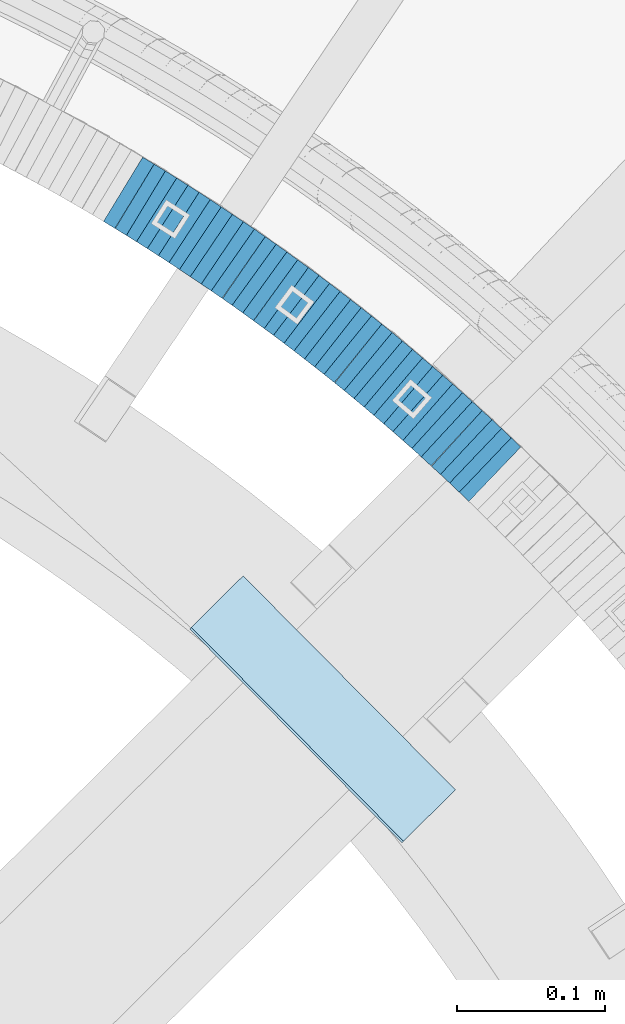
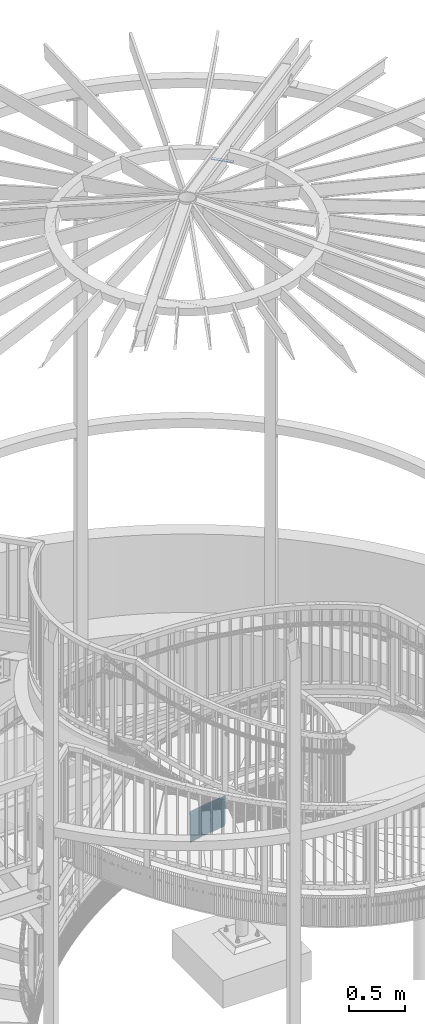
# One storey, part 899 of 975: 37 plates.
"""IFC2X3 building model written with IfcOpenShell, lengths in millimetres."""

from ifc_helpers import new_model, si_unit, frame, origin_with_axes, place, context, subcontext, project, spatial, faceted_brep, material, type_object, element, save


model = new_model("IFC2X3")

# Units and contexts
model_context = context("Model", 3, precision=1e-05, world=origin_with_axes())
body_context = subcontext(model_context, "Body", "Model", "MODEL_VIEW")
ifc_project = project(units=[si_unit("LENGTHUNIT", "METRE", prefix="MILLI"), si_unit("AREAUNIT", "SQUARE_METRE"), si_unit("VOLUMEUNIT", "CUBIC_METRE"), si_unit("MASSUNIT", "GRAM", prefix="KILO"), si_unit("TIMEUNIT", "SECOND"), si_unit("PLANEANGLEUNIT", "RADIAN"), si_unit("SOLIDANGLEUNIT", "STERADIAN"), si_unit("THERMODYNAMICTEMPERATUREUNIT", "DEGREE_CELSIUS"), si_unit("LUMINOUSINTENSITYUNIT", "LUMEN")], contexts=[model_context])

# Site, building, storey
site_placement = place(None, origin_with_axes())
site = spatial("IfcSite", under=ifc_project, at=site_placement, CompositionType="ELEMENT")
building_placement = place(site_placement, origin_with_axes())
building = spatial("IfcBuilding", under=site, at=building_placement, Name="Undefined", CompositionType="ELEMENT")
storey_placement = place(building_placement, origin_with_axes())
storey = spatial("IfcBuildingStorey", under=building, at=storey_placement, Name="Undefined", CompositionType="ELEMENT", Elevation=0.0)

# Plates
ifc_material = material(Name="STEEL/A36")
plate_type_1 = type_object("IfcPlateType", PredefinedType="NOTDEFINED")
plate_1_placement = place(storey_placement, frame((35697.4442044014, 4415.77790393961, 1760.80000000089), z_axis=(0.723608232244992, -0.690210928794435, 1.00843806194462e-10), x_axis=(0.0, 0.0, -1.0)))
element("IfcPlate", 1, at=plate_1_placement, inside=storey, type_object=plate_type_1, material=ifc_material, Name="WALL", context=body_context, shape_type="Brep", body=[
    faceted_brep([(0.0, -25.3999999999724, -1.81898940354586e-11), (-5.69999980926514, -25.3999999999833, 8.98053455353147), (-5.69999980926514, 25.3999999999396, 8.98053455348781), (0.0, 25.3999999999869, 1.45519152283669e-11), (299.100006103516, -25.3999999999833, 8.98053455353147), (299.100006103516, 25.3999999999396, 8.98053455348781), (304.799987792969, -25.3999999999724, -1.81898940354586e-11), (304.799987792969, 25.3999999999869, 1.45519152283669e-11)], [[[0, 1, 2, 3]], [[1, 4, 5, 2]], [[4, 6, 7, 5]], [[6, 0, 3, 7]], [[5, 7, 3, 2]], [[6, 4, 1, 0]]]),
])
plate_2_placement = place(storey_placement, frame((35690.9442043951, 4421.97790393989, 1755.00000000089), z_axis=(0.723608232244992, -0.690210928794435, 1.00843806194462e-10), x_axis=(0.0, 0.0, -1.0)))
element("IfcPlate", 2, at=plate_2_placement, inside=storey, type_object=plate_type_1, material=ifc_material, Name="WALL", context=body_context, shape_type="Brep", body=[
    faceted_brep([(0.0, -25.3999999999724, -1.81898940354586e-11), (-5.80000019073486, -25.3999999999542, 8.98276138308574), (-5.80000019073486, 25.3999999999469, 8.98276138302026), (0.0, 25.3999999999869, 1.45519152283669e-11), (299.0, -25.3999999999542, 8.98276138308574), (299.0, 25.3999999999469, 8.98276138302026), (304.799987792969, -25.3999999999724, -1.81898940354586e-11), (304.799987792969, 25.3999999999869, 1.45519152283669e-11)], [[[0, 1, 2, 3]], [[1, 4, 5, 2]], [[4, 6, 7, 5]], [[6, 0, 3, 7]], [[5, 7, 3, 2]], [[6, 4, 1, 0]]]),
])
plate_3_placement = place(storey_placement, frame((35684.5939812169, 4427.93619645336, 1749.30000000089), z_axis=(0.729187266868911, -0.684314204029295, 7.10215317667462e-11), x_axis=(0.0, 0.0, -1.0)))
element("IfcPlate", 3, at=plate_3_placement, inside=storey, type_object=plate_type_1, material=ifc_material, Name="WALL", context=body_context, shape_type="Brep", body=[
    faceted_brep([(0.0, -25.3999999999724, -1.81898940354586e-11), (-5.69999980926514, -25.400000000096, 8.9140338897214), (-5.69999980926514, 25.4000000000524, 8.91403388979779), (0.0, 25.3999999999869, 1.45519152283669e-11), (299.100006103516, -25.400000000096, 8.9140338897214), (299.100006103516, 25.4000000000524, 8.91403388979779), (304.799987792969, -25.3999999999724, -1.81898940354586e-11), (304.799987792969, 25.3999999999869, 1.45519152283669e-11)], [[[0, 1, 2, 3]], [[1, 4, 5, 2]], [[4, 6, 7, 5]], [[6, 0, 3, 7]], [[5, 7, 3, 2]], [[6, 4, 1, 0]]]),
])
plate_4_placement = place(storey_placement, frame((35678.2896730304, 4433.6630751744, 1743.5000000009), z_axis=(0.739940073305354, -0.672672794095961, -8.58849489304701e-11), x_axis=(0.0, 0.0, -1.0)))
element("IfcPlate", 4, at=plate_4_placement, inside=storey, type_object=plate_type_1, material=ifc_material, Name="WALL", context=body_context, shape_type="Brep", body=[
    faceted_brep([(0.0, -25.3999999999724, -1.81898940354586e-11), (-5.80000019073486, -25.3999999999724, 8.9196414947728), (-5.80000019073486, 25.4000000000342, 8.91964149478736), (0.0, 25.3999999999869, 1.45519152283669e-11), (299.0, -25.3999999999724, 8.9196414947728), (299.0, 25.4000000000342, 8.91964149478736), (304.799987792969, -25.3999999999724, -1.81898940354586e-11), (304.799987792969, 25.3999999999869, 1.45519152283669e-11)], [[[0, 1, 2, 3]], [[1, 4, 5, 2]], [[4, 6, 7, 5]], [[6, 0, 3, 7]], [[5, 7, 3, 2]], [[6, 4, 1, 0]]]),
])
plate_5_placement = place(storey_placement, frame((35671.5355124375, 4439.90438464906, 1737.8000000009), z_axis=(0.734376708367199, -0.678742108762789, -2.68556050286861e-10), x_axis=(0.0, 0.0, -1.0)))
element("IfcPlate", 5, at=plate_5_placement, inside=storey, type_object=plate_type_1, material=ifc_material, Name="WALL", context=body_context, shape_type="Brep", body=[
    faceted_brep([(0.0, -25.3999999999724, -1.81898940354586e-11), (-5.69999980926514, -25.3999999999724, 8.9872131347729), (-5.69999980926514, 25.3999999999833, 8.98721313475835), (0.0, 25.3999999999869, 1.45519152283669e-11), (299.100006103516, -25.3999999999724, 8.9872131347729), (299.100006103516, 25.3999999999833, 8.98721313475835), (304.799987792969, -25.3999999999724, -1.81898940354586e-11), (304.799987792969, 25.3999999999869, 1.45519152283669e-11)], [[[0, 1, 2, 3]], [[1, 4, 5, 2]], [[4, 6, 7, 5]], [[6, 0, 3, 7]], [[5, 7, 3, 2]], [[6, 4, 1, 0]]]),
])
plate_6_placement = place(storey_placement, frame((35665.0896730412, 4445.76307517438, 1732.1000000009), z_axis=(0.739940073305354, -0.672672794095961, -8.58849489304701e-11), x_axis=(0.0, 0.0, -1.0)))
element("IfcPlate", 6, at=plate_6_placement, inside=storey, type_object=plate_type_1, material=ifc_material, Name="WALL", context=body_context, shape_type="Brep", body=[
    faceted_brep([(0.0, -25.3999999999724, -1.81898940354586e-11), (-5.69999980926514, -25.3999999999724, 8.91964149478372), (-5.69999980926514, 25.400000000016, 8.9196414947528), (0.0, 25.3999999999869, 1.45519152283669e-11), (299.100006103516, -25.3999999999724, 8.91964149478372), (299.100006103516, 25.400000000016, 8.9196414947528), (304.799987792969, -25.3999999999724, -1.81898940354586e-11), (304.799987792969, 25.3999999999869, 1.45519152283669e-11)], [[[0, 1, 2, 3]], [[1, 4, 5, 2]], [[4, 6, 7, 5]], [[6, 0, 3, 7]], [[5, 7, 3, 2]], [[6, 4, 1, 0]]]),
])
plate_7_placement = place(storey_placement, frame((35658.6892006673, 4451.39507489995, 1726.30000000089), z_axis=(0.750491265210869, -0.660880368026006, -7.65185177442618e-11), x_axis=(0.0, 0.0, -1.0)))
element("IfcPlate", 7, at=plate_7_placement, inside=storey, type_object=plate_type_1, material=ifc_material, Name="WALL", context=body_context, shape_type="Brep", body=[
    faceted_brep([(0.0, -25.3999999999724, -1.81898940354586e-11), (-5.80000019073486, -25.399999999976, 8.9274854660398), (-5.80000019073486, 25.4000000000269, 8.92748546601433), (0.0, 25.3999999999869, 1.45519152283669e-11), (299.0, -25.399999999976, 8.9274854660398), (299.0, 25.4000000000269, 8.92748546601433), (304.799987792969, -25.3999999999724, -1.81898940354586e-11), (304.799987792969, 25.3999999999869, 1.45519152283669e-11)], [[[0, 1, 2, 3]], [[1, 4, 5, 2]], [[4, 6, 7, 5]], [[6, 0, 3, 7]], [[5, 7, 3, 2]], [[6, 4, 1, 0]]]),
])
plate_8_placement = place(storey_placement, frame((35651.989200671, 4457.29507489991, 1720.60000000087), z_axis=(0.750491265210869, -0.660880368026006, -7.65185177442618e-11), x_axis=(0.0, 0.0, -1.0)))
element("IfcPlate", 8, at=plate_8_placement, inside=storey, type_object=plate_type_1, material=ifc_material, Name="WALL", context=body_context, shape_type="Brep", body=[
    faceted_brep([(0.0, -25.3999999999724, -1.81898940354586e-11), (-5.69999980926514, -25.3999999999141, 8.92748546604707), (-5.69999980926514, 25.3999999999505, 8.92748546598159), (0.0, 25.3999999999869, 1.45519152283669e-11), (299.100006103516, -25.3999999999141, 8.92748546604707), (299.100006103516, 25.3999999999505, 8.92748546598159), (304.799987792969, -25.3999999999724, -1.81898940354586e-11), (304.799987792969, 25.3999999999869, 1.45519152283669e-11)], [[[0, 1, 2, 3]], [[1, 4, 5, 2]], [[4, 6, 7, 5]], [[6, 0, 3, 7]], [[5, 7, 3, 2]], [[6, 4, 1, 0]]]),
])
plate_9_placement = place(storey_placement, frame((35645.4923182328, 4462.83237065359, 1714.90000000086), z_axis=(0.760833952037136, -0.648946605991242, -1.96182554645929e-11), x_axis=(0.0, 0.0, -1.0)))
element("IfcPlate", 9, at=plate_9_placement, inside=storey, type_object=plate_type_1, material=ifc_material, Name="WALL", context=body_context, shape_type="Brep", body=[
    faceted_brep([(0.0, -25.3999999999724, -1.81898940354586e-11), (-5.69999980926514, -25.4000000000415, 8.93756103511259), (-5.69999980926514, 25.4000000000815, 8.93756103522537), (0.0, 25.3999999999869, 1.45519152283669e-11), (299.100006103516, -25.4000000000415, 8.93756103511259), (299.100006103516, 25.4000000000815, 8.93756103522537), (304.799987792969, -25.3999999999724, -1.81898940354586e-11), (304.799987792969, 25.3999999999869, 1.45519152283669e-11)], [[[0, 1, 2, 3]], [[1, 4, 5, 2]], [[4, 6, 7, 5]], [[6, 0, 3, 7]], [[5, 7, 3, 2]], [[6, 4, 1, 0]]]),
])
plate_10_placement = place(storey_placement, frame((35638.6923182373, 4468.63237065311, 1709.10000000085), z_axis=(0.760833952037136, -0.648946605991242, -1.96182554645929e-11), x_axis=(0.0, 0.0, -1.0)))
element("IfcPlate", 10, at=plate_10_placement, inside=storey, type_object=plate_type_1, material=ifc_material, Name="WALL", context=body_context, shape_type="Brep", body=[
    faceted_brep([(0.0, -25.3999999999724, -1.81898940354586e-11), (-5.80000019073486, -25.3999999999287, 8.93756103519445), (-5.80000019073486, 25.399999999936, 8.93756103512169), (0.0, 25.3999999999869, 1.45519152283669e-11), (299.0, -25.3999999999287, 8.93756103519445), (299.0, 25.399999999936, 8.93756103512169), (304.799987792969, -25.3999999999724, -1.81898940354586e-11), (304.799987792969, 25.3999999999869, 1.45519152283669e-11)], [[[0, 1, 2, 3]], [[1, 4, 5, 2]], [[4, 6, 7, 5]], [[6, 0, 3, 7]], [[5, 7, 3, 2]], [[6, 4, 1, 0]]]),
])
plate_11_placement = place(storey_placement, frame((35631.8923182418, 4474.43237065354, 1703.40000000084), z_axis=(0.760833952037136, -0.648946605991242, -1.96182554645929e-11), x_axis=(0.0, 0.0, -1.0)))
element("IfcPlate", 11, at=plate_11_placement, inside=storey, type_object=plate_type_1, material=ifc_material, Name="WALL", context=body_context, shape_type="Brep", body=[
    faceted_brep([(0.0, -25.3999999999724, -1.81898940354586e-11), (-5.69999980926514, -25.4000000000415, 8.93756103511259), (-5.69999980926514, 25.4000000000815, 8.93756103522537), (0.0, 25.3999999999869, 1.45519152283669e-11), (299.100006103516, -25.4000000000415, 8.93756103511259), (299.100006103516, 25.4000000000815, 8.93756103522537), (304.799987792969, -25.3999999999724, -1.81898940354586e-11), (304.799987792969, 25.3999999999869, 1.45519152283669e-11)], [[[0, 1, 2, 3]], [[1, 4, 5, 2]], [[4, 6, 7, 5]], [[6, 0, 3, 7]], [[5, 7, 3, 2]], [[6, 4, 1, 0]]]),
])
plate_12_placement = place(storey_placement, frame((35625.2586321824, 4479.99174197565, 1697.70000000083), z_axis=(0.766370513915105, -0.642398813356235, 2.14107785723172e-10), x_axis=(0.0, 0.0, -1.0)))
element("IfcPlate", 12, at=plate_12_placement, inside=storey, type_object=plate_type_1, material=ifc_material, Name="WALL", context=body_context, shape_type="Brep", body=[
    faceted_brep([(0.0, -25.3999999999724, -1.81898940354586e-11), (-5.69999980926514, -25.4000000000378, 8.86848354337781), (-5.69999980926514, 25.4000000000451, 8.86848354342146), (0.0, 25.3999999999869, 1.45519152283669e-11), (299.100006103516, -25.4000000000378, 8.86848354337781), (299.100006103516, 25.4000000000451, 8.86848354342146), (304.799987792969, -25.3999999999724, -1.81898940354586e-11), (304.799987792969, 25.3999999999869, 1.45519152283669e-11)], [[[0, 1, 2, 3]], [[1, 4, 5, 2]], [[4, 6, 7, 5]], [[6, 0, 3, 7]], [[5, 7, 3, 2]], [[6, 4, 1, 0]]]),
])
plate_13_placement = place(storey_placement, frame((35618.4987732912, 4485.5751245397, 1692.00000000082), z_axis=(0.770961751776529, -0.636881446815391, 0.0), x_axis=(0.0, 0.0, -1.0)))
element("IfcPlate", 13, at=plate_13_placement, inside=storey, type_object=plate_type_1, material=ifc_material, Name="WALL", context=body_context, shape_type="Brep", body=[
    faceted_brep([(0.0, -25.3999999999724, -1.81898940354586e-11), (-5.69999980926514, -25.4000000000451, 8.94986057279493), (-5.69999980926514, 25.3999999999942, 8.94986057280948), (0.0, 25.3999999999869, 1.45519152283669e-11), (299.100006103516, -25.4000000000451, 8.94986057279493), (299.100006103516, 25.3999999999942, 8.94986057280948), (304.799987792969, -25.3999999999724, -1.81898940354586e-11), (304.799987792969, 25.3999999999869, 1.45519152283669e-11)], [[[0, 1, 2, 3]], [[1, 4, 5, 2]], [[4, 6, 7, 5]], [[6, 0, 3, 7]], [[5, 7, 3, 2]], [[6, 4, 1, 0]]]),
])
plate_14_placement = place(storey_placement, frame((35611.8083078211, 4490.92348528417, 1686.20000000082), z_axis=(0.780868809491731, -0.624695047493549, -4.54620931122918e-10), x_axis=(0.0, 0.0, -1.0)))
element("IfcPlate", 14, at=plate_14_placement, inside=storey, type_object=plate_type_1, material=ifc_material, Name="WALL", context=body_context, shape_type="Brep", body=[
    faceted_brep([(0.0, -25.3999999999724, -1.81898940354586e-11), (-5.80000019073486, -25.3999999999396, 8.9627008438656), (-5.80000019073486, 25.3999999999178, 8.96270084374191), (0.0, 25.3999999999869, 1.45519152283669e-11), (299.0, -25.3999999999396, 8.9627008438656), (299.0, 25.3999999999178, 8.96270084374191), (304.799987792969, -25.3999999999724, -1.81898940354586e-11), (304.799987792969, 25.3999999999869, 1.45519152283669e-11)], [[[0, 1, 2, 3]], [[1, 4, 5, 2]], [[4, 6, 7, 5]], [[6, 0, 3, 7]], [[5, 7, 3, 2]], [[6, 4, 1, 0]]]),
])
plate_15_placement = place(storey_placement, frame((35604.7692722815, 4496.63551743752, 1680.50000000081), z_axis=(0.776458094539456, -0.630168888016663, -2.13430666917702e-10), x_axis=(0.0, 0.0, -1.0)))
element("IfcPlate", 15, at=plate_15_placement, inside=storey, type_object=plate_type_1, material=ifc_material, Name="WALL", context=body_context, shape_type="Brep", body=[
    faceted_brep([(0.0, -25.3999999999724, -1.81898940354586e-11), (-5.69999980926514, -25.4000000000487, 8.88650703422172), (-5.69999980926514, 25.4000000000524, 8.88650703437088), (0.0, 25.3999999999869, 1.45519152283669e-11), (299.100006103516, -25.4000000000487, 8.88650703422172), (299.100006103516, 25.4000000000524, 8.88650703437088), (304.799987792969, -25.3999999999724, -1.81898940354586e-11), (304.799987792969, 25.3999999999869, 1.45519152283669e-11)], [[[0, 1, 2, 3]], [[1, 4, 5, 2]], [[4, 6, 7, 5]], [[6, 0, 3, 7]], [[5, 7, 3, 2]], [[6, 4, 1, 0]]]),
])
plate_16_placement = place(storey_placement, frame((35598.082894629, 4501.88506722711, 1674.80000000081), z_axis=(0.786318338803255, -0.617821551956298, 5.58256942895241e-11), x_axis=(0.0, 0.0, -1.0)))
element("IfcPlate", 16, at=plate_16_placement, inside=storey, type_object=plate_type_1, material=ifc_material, Name="WALL", context=body_context, shape_type="Brep", body=[
    faceted_brep([(0.0, -25.3999999999724, -1.81898940354586e-11), (-5.69999980926514, -25.3999999999724, 8.90224647524519), (-5.69999980926514, 25.3999999999542, 8.90224647519426), (0.0, 25.3999999999869, 1.45519152283669e-11), (299.100006103516, -25.3999999999724, 8.90224647524519), (299.100006103516, 25.3999999999542, 8.90224647519426), (304.799987792969, -25.3999999999724, -1.81898940354586e-11), (304.799987792969, 25.3999999999869, 1.45519152283669e-11)], [[[0, 1, 2, 3]], [[1, 4, 5, 2]], [[4, 6, 7, 5]], [[6, 0, 3, 7]], [[5, 7, 3, 2]], [[6, 4, 1, 0]]]),
])
plate_17_placement = place(storey_placement, frame((35591.1206594005, 4507.27758780561, 1669.0000000008), z_axis=(0.790549812362229, -0.612397741810046, -2.3609345589648e-10), x_axis=(0.0, 0.0, -1.0)))
element("IfcPlate", 17, at=plate_17_placement, inside=storey, type_object=plate_type_1, material=ifc_material, Name="WALL", context=body_context, shape_type="Brep", body=[
    faceted_brep([(0.0, -25.3999999999724, -1.81898940354586e-11), (-5.80000019073486, -25.3999999999542, 8.98276138308574), (-5.80000019073486, 25.3999999999469, 8.98276138302026), (0.0, 25.3999999999869, 1.45519152283669e-11), (299.0, -25.3999999999542, 8.98276138308574), (299.0, 25.3999999999469, 8.98276138302026), (304.799987792969, -25.3999999999724, -1.81898940354586e-11), (304.799987792969, 25.3999999999869, 1.45519152283669e-11)], [[[0, 1, 2, 3]], [[1, 4, 5, 2]], [[4, 6, 7, 5]], [[6, 0, 3, 7]], [[5, 7, 3, 2]], [[6, 4, 1, 0]]]),
])
plate_18_placement = place(storey_placement, frame((35584.0206594035, 4512.77758780551, 1663.3000000008), z_axis=(0.790549812362229, -0.612397741810046, -2.3609345589648e-10), x_axis=(0.0, 0.0, -1.0)))
element("IfcPlate", 18, at=plate_18_placement, inside=storey, type_object=plate_type_1, material=ifc_material, Name="WALL", context=body_context, shape_type="Brep", body=[
    faceted_brep([(0.0, -25.3999999999724, -1.81898940354586e-11), (-5.69999980926514, -25.3999999999833, 8.98053455353147), (-5.69999980926514, 25.3999999999396, 8.98053455348781), (0.0, 25.3999999999869, 1.45519152283669e-11), (299.100006103516, -25.3999999999833, 8.98053455353147), (299.100006103516, 25.3999999999396, 8.98053455348781), (304.799987792969, -25.3999999999724, -1.81898940354586e-11), (304.799987792969, 25.3999999999869, 1.45519152283669e-11)], [[[0, 1, 2, 3]], [[1, 4, 5, 2]], [[4, 6, 7, 5]], [[6, 0, 3, 7]], [[5, 7, 3, 2]], [[6, 4, 1, 0]]]),
])
for number, where, z_axis, x_axis, name in (
    (19, (35577.0992282819, 4518.04052160415, 1657.60000000079), (0.795946119300868, -0.605367471185798, -2.1885171008762e-11), (0.0, 0.0, -1.0), "WALL"),
    (20, (35569.9992282796, 4523.44052160392, 1651.90000000078), (0.795946119300868, -0.605367471185798, -2.1885171008762e-11), (0.0, 0.0, -1.0), "WALL"),
):
    element("IfcPlate", number, at=place(storey_placement, frame(where, z_axis=z_axis, x_axis=x_axis)), inside=storey, type_object=plate_type_1, material=ifc_material, Name=name, context=body_context, shape_type="Brep", body=[
        faceted_brep([(0.0, -25.3999999999724, -1.81898940354586e-11), (-5.69999980926514, -25.3999999999724, 8.91964149478372), (-5.69999980926514, 25.400000000016, 8.9196414947528), (0.0, 25.3999999999869, 1.45519152283669e-11), (299.100006103516, -25.3999999999724, 8.91964149478372), (299.100006103516, 25.400000000016, 8.9196414947528), (304.799987792969, -25.3999999999724, -1.81898940354586e-11), (304.799987792969, 25.3999999999869, 1.45519152283669e-11)], [[[0, 1, 2, 3]], [[1, 4, 5, 2]], [[4, 6, 7, 5]], [[6, 0, 3, 7]], [[5, 7, 3, 2]], [[6, 4, 1, 0]]]),
    ])
plate_19_placement = place(storey_placement, frame((35563.1179993727, 4528.50199617598, 1646.10000000077), z_axis=(0.805336883996211, -0.592817428282328, 1.46393176692072e-10), x_axis=(0.0, 0.0, -1.0)))
element("IfcPlate", 21, at=plate_19_placement, inside=storey, type_object=plate_type_1, material=ifc_material, Name="WALL", context=body_context, shape_type="Brep", body=[
    faceted_brep([(0.0, -25.3999999999724, -1.81898940354586e-11), (-5.80000019073486, -25.3999999999287, 8.93756103519445), (-5.80000019073486, 25.399999999936, 8.93756103512169), (0.0, 25.3999999999869, 1.45519152283669e-11), (299.0, -25.3999999999287, 8.93756103519445), (299.0, 25.399999999936, 8.93756103512169), (304.799987792969, -25.3999999999724, -1.81898940354586e-11), (304.799987792969, 25.3999999999869, 1.45519152283669e-11)], [[[0, 1, 2, 3]], [[1, 4, 5, 2]], [[4, 6, 7, 5]], [[6, 0, 3, 7]], [[5, 7, 3, 2]], [[6, 4, 1, 0]]]),
])
plate_20_placement = place(storey_placement, frame((35556.1041019705, 4533.56630063727, 1640.40000000076), z_axis=(0.810679228188928, -0.585490554136447, 0.0), x_axis=(0.0, 0.0, -1.0)))
element("IfcPlate", 22, at=plate_20_placement, inside=storey, type_object=plate_type_1, material=ifc_material, Name="WALL", context=body_context, shape_type="Brep", body=[
    faceted_brep([(0.0, -25.3999999999724, -1.81898940354586e-11), (-5.69999980926514, -25.4000000000669, 8.8814411163039), (-5.69999980926514, 25.400000000096, 8.88144111637848), (0.0, 25.3999999999869, 1.45519152283669e-11), (299.100006103516, -25.4000000000669, 8.8814411163039), (299.100006103516, 25.400000000096, 8.88144111637848), (304.799987792969, -25.3999999999724, -1.81898940354586e-11), (304.799987792969, 25.3999999999869, 1.45519152283669e-11)], [[[0, 1, 2, 3]], [[1, 4, 5, 2]], [[4, 6, 7, 5]], [[6, 0, 3, 7]], [[5, 7, 3, 2]], [[6, 4, 1, 0]]]),
])
plate_21_placement = place(storey_placement, frame((35548.7527474449, 4538.9034876383, 1634.60000000076), z_axis=(0.809215172970906, -0.587512386110852, 6.74795046506914e-11), x_axis=(0.0, 0.0, -1.0)))
element("IfcPlate", 23, at=plate_21_placement, inside=storey, type_object=plate_type_1, material=ifc_material, Name="WALL", context=body_context, shape_type="Brep", body=[
    faceted_brep([(0.0, -25.3999999999724, -1.81898940354586e-11), (-5.80000019073486, -25.4000000000051, 9.02108669279187), (-5.80000019073486, 25.3999999999724, 9.02108669278459), (0.0, 25.3999999999869, 1.45519152283669e-11), (299.0, -25.4000000000051, 9.02108669279187), (299.0, 25.3999999999724, 9.02108669278459), (304.799987792969, -25.3999999999724, -1.81898940354586e-11), (304.799987792969, 25.3999999999869, 1.45519152283669e-11)], [[[0, 1, 2, 3]], [[1, 4, 5, 2]], [[4, 6, 7, 5]], [[6, 0, 3, 7]], [[5, 7, 3, 2]], [[6, 4, 1, 0]]]),
])
plate_22_placement = place(storey_placement, frame((35541.6041019742, 4544.06630063766, 1628.90000000075), z_axis=(0.810679228188928, -0.585490554136447, 0.0), x_axis=(0.0, 0.0, -1.0)))
element("IfcPlate", 24, at=plate_22_placement, inside=storey, type_object=plate_type_1, material=ifc_material, Name="WALL", context=body_context, shape_type="Brep", body=[
    faceted_brep([(0.0, -25.3999999999724, -1.81898940354586e-11), (-5.69999980926514, -25.4000000000669, 8.8814411163039), (-5.69999980926514, 25.400000000096, 8.88144111637848), (0.0, 25.3999999999869, 1.45519152283669e-11), (299.100006103516, -25.4000000000669, 8.8814411163039), (299.100006103516, 25.400000000096, 8.88144111637848), (304.799987792969, -25.3999999999724, -1.81898940354586e-11), (304.799987792969, 25.3999999999869, 1.45519152283669e-11)], [[[0, 1, 2, 3]], [[1, 4, 5, 2]], [[4, 6, 7, 5]], [[6, 0, 3, 7]], [[5, 7, 3, 2]], [[6, 4, 1, 0]]]),
])
plate_23_placement = place(storey_placement, frame((35534.6617501142, 4548.84339453943, 1623.20000000075), z_axis=(0.823392066898081, -0.567472910515828, 1.08082133465359e-10), x_axis=(0.0, 0.0, -1.0)))
element("IfcPlate", 25, at=plate_23_placement, inside=storey, type_object=plate_type_1, material=ifc_material, Name="WALL", context=body_context, shape_type="Brep", body=[
    faceted_brep([(0.0, -25.3999999999724, -1.81898940354586e-11), (-5.69999980926514, -25.3999999999724, 8.9872131347729), (-5.69999980926514, 25.3999999999833, 8.98721313475835), (0.0, 25.3999999999869, 1.45519152283669e-11), (299.100006103516, -25.3999999999724, 8.9872131347729), (299.100006103516, 25.3999999999833, 8.98721313475835), (304.799987792969, -25.3999999999724, -1.81898940354586e-11), (304.799987792969, 25.3999999999869, 1.45519152283669e-11)], [[[0, 1, 2, 3]], [[1, 4, 5, 2]], [[4, 6, 7, 5]], [[6, 0, 3, 7]], [[5, 7, 3, 2]], [[6, 4, 1, 0]]]),
])
plate_24_placement = place(storey_placement, frame((35527.2287677047, 4554.0356709332, 1617.40000000075), z_axis=(0.819759137986819, -0.572708438637941, -1.85146291187266e-10), x_axis=(0.0, 0.0, -1.0)))
element("IfcPlate", 26, at=plate_24_placement, inside=storey, type_object=plate_type_1, material=ifc_material, Name="WALL", context=body_context, shape_type="Brep", body=[
    faceted_brep([(0.0, -25.3999999999724, -1.81898940354586e-11), (-5.80000019073486, -25.399999999976, 8.91066741944087), (-5.80000019073486, 25.4000000000051, 8.91066741945178), (0.0, 25.3999999999869, 1.45519152283669e-11), (299.0, -25.399999999976, 8.91066741944087), (299.0, 25.4000000000051, 8.91066741945178), (304.799987792969, -25.3999999999724, -1.81898940354586e-11), (304.799987792969, 25.3999999999869, 1.45519152283669e-11)], [[[0, 1, 2, 3]], [[1, 4, 5, 2]], [[4, 6, 7, 5]], [[6, 0, 3, 7]], [[5, 7, 3, 2]], [[6, 4, 1, 0]]]),
])
plate_25_placement = place(storey_placement, frame((35520.1551838107, 4558.81139322327, 1611.70000000075), z_axis=(0.828588968904653, -0.559857410962403, 1.41858436109032e-11), x_axis=(0.0, 0.0, -1.0)))
element("IfcPlate", 27, at=plate_25_placement, inside=storey, type_object=plate_type_1, material=ifc_material, Name="WALL", context=body_context, shape_type="Brep", body=[
    faceted_brep([(0.0, -25.3999999999724, -1.81898940354586e-11), (-5.69999980926514, -25.3999999999141, 8.92748546604707), (-5.69999980926514, 25.3999999999505, 8.92748546598159), (0.0, 25.3999999999869, 1.45519152283669e-11), (299.100006103516, -25.3999999999141, 8.92748546604707), (299.100006103516, 25.3999999999505, 8.92748546598159), (304.799987792969, -25.3999999999724, -1.81898940354586e-11), (304.799987792969, 25.3999999999869, 1.45519152283669e-11)], [[[0, 1, 2, 3]], [[1, 4, 5, 2]], [[4, 6, 7, 5]], [[6, 0, 3, 7]], [[5, 7, 3, 2]], [[6, 4, 1, 0]]]),
])
plate_26_placement = place(storey_placement, frame((35512.7551838073, 4563.81139322264, 1605.90000000075), z_axis=(0.828588968904653, -0.559857410962403, 1.41858436109032e-11), x_axis=(0.0, 0.0, -1.0)))
element("IfcPlate", 28, at=plate_26_placement, inside=storey, type_object=plate_type_1, material=ifc_material, Name="WALL", context=body_context, shape_type="Brep", body=[
    faceted_brep([(0.0, -25.3999999999724, -1.81898940354586e-11), (-5.80000019073486, -25.399999999976, 8.9274854660398), (-5.80000019073486, 25.4000000000269, 8.92748546601433), (0.0, 25.3999999999869, 1.45519152283669e-11), (299.0, -25.399999999976, 8.9274854660398), (299.0, 25.4000000000269, 8.92748546601433), (304.799987792969, -25.3999999999724, -1.81898940354586e-11), (304.799987792969, 25.3999999999869, 1.45519152283669e-11)], [[[0, 1, 2, 3]], [[1, 4, 5, 2]], [[4, 6, 7, 5]], [[6, 0, 3, 7]], [[5, 7, 3, 2]], [[6, 4, 1, 0]]]),
])
plate_27_placement = place(storey_placement, frame((35505.3861770613, 4568.7234755568, 1600.20000000074), z_axis=(0.832050294337872, -0.554700196225187, 1.688249540166e-14), x_axis=(0.0, 0.0, -1.0)))
element("IfcPlate", 29, at=plate_27_placement, inside=storey, type_object=plate_type_1, material=ifc_material, Name="WALL", context=body_context, shape_type="Brep", body=[
    faceted_brep([(0.0, -25.3999999999724, -1.81898940354586e-11), (-5.69999980926514, -25.4000000000087, 9.01387786864507), (-5.69999980926514, 25.4000000000124, 9.0138778686669), (0.0, 25.3999999999869, 1.45519152283669e-11), (299.100006103516, -25.4000000000087, 9.01387786864507), (299.100006103516, 25.4000000000124, 9.0138778686669), (304.799987792969, -25.3999999999724, -1.81898940354586e-11), (304.799987792969, 25.3999999999869, 1.45519152283669e-11)], [[[0, 1, 2, 3]], [[1, 4, 5, 2]], [[4, 6, 7, 5]], [[6, 0, 3, 7]], [[5, 7, 3, 2]], [[6, 4, 1, 0]]]),
])
plate_28_placement = place(storey_placement, frame((35498.0830680113, 4573.49353155232, 1594.50000000074), z_axis=(0.837166200072577, -0.546948583923609, -6.59451870888006e-11), x_axis=(0.0, 0.0, -1.0)))
element("IfcPlate", 30, at=plate_28_placement, inside=storey, type_object=plate_type_1, material=ifc_material, Name="WALL", context=body_context, shape_type="Brep", body=[
    faceted_brep([(0.0, -25.3999999999724, -1.81898940354586e-11), (-5.69999980926514, -25.4000000000087, 8.9643735885511), (-5.69999980926514, 25.4000000000669, 8.96437358860567), (0.0, 25.3999999999869, 1.45519152283669e-11), (299.100006103516, -25.4000000000087, 8.9643735885511), (299.100006103516, 25.4000000000669, 8.96437358860567), (304.799987792969, -25.3999999999724, -1.81898940354586e-11), (304.799987792969, 25.3999999999869, 1.45519152283669e-11)], [[[0, 1, 2, 3]], [[1, 4, 5, 2]], [[4, 6, 7, 5]], [[6, 0, 3, 7]], [[5, 7, 3, 2]], [[6, 4, 1, 0]]]),
])
plate_29_placement = place(storey_placement, frame((35490.583068011, 4578.39353155205, 1588.70000000074), z_axis=(0.837166200072577, -0.546948583923609, -6.59451870888006e-11), x_axis=(0.0, 0.0, -1.0)))
element("IfcPlate", 31, at=plate_29_placement, inside=storey, type_object=plate_type_1, material=ifc_material, Name="WALL", context=body_context, shape_type="Brep", body=[
    faceted_brep([(0.0, -25.3999999999724, -1.81898940354586e-11), (-5.80000019073486, -25.3999999999396, 8.9627008438656), (-5.80000019073486, 25.3999999999178, 8.96270084374191), (0.0, 25.3999999999869, 1.45519152283669e-11), (299.0, -25.3999999999396, 8.9627008438656), (299.0, 25.3999999999178, 8.96270084374191), (304.799987792969, -25.3999999999724, -1.81898940354586e-11), (304.799987792969, 25.3999999999869, 1.45519152283669e-11)], [[[0, 1, 2, 3]], [[1, 4, 5, 2]], [[4, 6, 7, 5]], [[6, 0, 3, 7]], [[5, 7, 3, 2]], [[6, 4, 1, 0]]]),
])
plate_30_placement = place(storey_placement, frame((35483.2835981637, 4583.06385944792, 1583.00000000073), z_axis=(0.842271400700033, -0.539053696363177, 2.99316525342875e-10), x_axis=(0.0, 0.0, -1.0)))
element("IfcPlate", 32, at=plate_30_placement, inside=storey, type_object=plate_type_1, material=ifc_material, Name="WALL", context=body_context, shape_type="Brep", body=[
    faceted_brep([(0.0, -25.3999999999724, -1.81898940354586e-11), (-5.69999980926514, -25.3999999999724, 8.90224647524519), (-5.69999980926514, 25.3999999999542, 8.90224647519426), (0.0, 25.3999999999869, 1.45519152283669e-11), (299.100006103516, -25.3999999999724, 8.90224647524519), (299.100006103516, 25.3999999999542, 8.90224647519426), (304.799987792969, -25.3999999999724, -1.81898940354586e-11), (304.799987792969, 25.3999999999869, 1.45519152283669e-11)], [[[0, 1, 2, 3]], [[1, 4, 5, 2]], [[4, 6, 7, 5]], [[6, 0, 3, 7]], [[5, 7, 3, 2]], [[6, 4, 1, 0]]]),
])
plate_31_placement = place(storey_placement, frame((35475.8121400695, 4587.78213489096, 1577.20000000073), z_axis=(0.845488903158904, -0.533992991185421, 4.56034285889473e-11), x_axis=(0.0, 0.0, -1.0)))
element("IfcPlate", 33, at=plate_31_placement, inside=storey, type_object=plate_type_1, material=ifc_material, Name="WALL", context=body_context, shape_type="Brep", body=[
    faceted_brep([(0.0, -25.3999999999724, -1.81898940354586e-11), (-5.80000019073486, -25.3999999999796, 8.98721313478018), (-5.80000019073486, 25.399999999936, 8.98721313473106), (0.0, 25.3999999999869, 1.45519152283669e-11), (299.0, -25.3999999999796, 8.98721313478018), (299.0, 25.399999999936, 8.98721313473106), (304.799987792969, -25.3999999999724, -1.81898940354586e-11), (304.799987792969, 25.3999999999869, 1.45519152283669e-11)], [[[0, 1, 2, 3]], [[1, 4, 5, 2]], [[4, 6, 7, 5]], [[6, 0, 3, 7]], [[5, 7, 3, 2]], [[6, 4, 1, 0]]]),
])
plate_32_placement = place(storey_placement, frame((35468.2121400721, 4592.58213489094, 1571.50000000072), z_axis=(0.845488903158904, -0.533992991185421, 4.56034285889473e-11), x_axis=(0.0, 0.0, -1.0)))
element("IfcPlate", 34, at=plate_32_placement, inside=storey, type_object=plate_type_1, material=ifc_material, Name="WALL", context=body_context, shape_type="Brep", body=[
    faceted_brep([(0.0, -25.3999999999724, -1.81898940354586e-11), (-5.69999980926514, -25.3999999999724, 8.9872131347729), (-5.69999980926514, 25.3999999999833, 8.98721313475835), (0.0, 25.3999999999869, 1.45519152283669e-11), (299.100006103516, -25.3999999999724, 8.9872131347729), (299.100006103516, 25.3999999999833, 8.98721313475835), (304.799987792969, -25.3999999999724, -1.81898940354586e-11), (304.799987792969, 25.3999999999869, 1.45519152283669e-11)], [[[0, 1, 2, 3]], [[1, 4, 5, 2]], [[4, 6, 7, 5]], [[6, 0, 3, 7]], [[5, 7, 3, 2]], [[6, 4, 1, 0]]]),
])
plate_33_placement = place(storey_placement, frame((35461.0233740048, 4596.92785102091, 1565.70000000071), z_axis=(0.855500079109598, -0.517802679254822, 1.05275375972269e-10), x_axis=(0.0, 0.0, -1.0)))
element("IfcPlate", 35, at=plate_33_placement, inside=storey, type_object=plate_type_1, material=ifc_material, Name="WALL", context=body_context, shape_type="Brep", body=[
    faceted_brep([(0.0, -25.3999999999724, -1.81898940354586e-11), (-5.80000019073486, -25.4000000000015, 8.88144111634028), (-5.80000019073486, 25.4000000000269, 8.88144111639849), (0.0, 25.3999999999869, 1.45519152283669e-11), (299.0, -25.4000000000015, 8.88144111634028), (299.0, 25.4000000000269, 8.88144111639849), (304.799987792969, -25.3999999999724, -1.81898940354586e-11), (304.799987792969, 25.3999999999869, 1.45519152283669e-11)], [[[0, 1, 2, 3]], [[1, 4, 5, 2]], [[4, 6, 7, 5]], [[6, 0, 3, 7]], [[5, 7, 3, 2]], [[6, 4, 1, 0]]]),
])
plate_34_placement = place(storey_placement, frame((35453.2421226873, 4601.67723747605, 1560.0000000007), z_axis=(0.853555730562404, -0.521001549732897, 0.0), x_axis=(0.0, 0.0, -1.0)))
element("IfcPlate", 36, at=plate_34_placement, inside=storey, type_object=plate_type_1, material=ifc_material, Name="WALL", context=body_context, shape_type="Brep", body=[
    faceted_brep([(0.0, -25.3999999999724, -1.81898940354586e-11), (-5.69999980926514, -25.4000000000269, 9.02108669276276), (-5.69999980926514, 25.4000000000487, 9.02108669289737), (0.0, 25.3999999999869, 1.45519152283669e-11), (299.100006103516, -25.4000000000269, 9.02108669276276), (299.100006103516, 25.4000000000487, 9.02108669289737), (304.799987792969, -25.3999999999724, -1.81898940354586e-11), (304.799987792969, 25.3999999999869, 1.45519152283669e-11)], [[[0, 1, 2, 3]], [[1, 4, 5, 2]], [[4, 6, 7, 5]], [[6, 0, 3, 7]], [[5, 7, 3, 2]], [[6, 4, 1, 0]]]),
])
plate_type_2 = type_object("IfcPlateType", PredefinedType="NOTDEFINED")
plate_35_placement = place(storey_placement, frame((35676.7839836258, 4196.2375415062, 8843.5048341401), z_axis=(-0.688502112820794, -0.683475127155158, 0.242541936995532), x_axis=(-0.704511181200153, 0.709692888201625, 9.99996585988633e-10)))
element("IfcPlate", 37, at=plate_35_placement, inside=storey, type_object=plate_type_2, material=ifc_material, Name="PLATE", context=body_context, shape_type="Brep", body=[
    faceted_brep([(0.0, -3.17499999999927, 0.0), (0.0, -3.17500000000882, 50.7999992370605), (0.0, 3.17499999999109, 50.7999992370678), (0.0, 3.17499999999927, 0.0), (203.199996947696, -3.17500000024665, 50.7999992364676), (203.1999969477, 3.17499999975553, 50.7999992364748), (203.199996947791, -3.17500000022483, -3.56521923094988e-10), (203.199996947806, 3.17499999978281, -3.41970007866621e-10)], [[[0, 1, 2, 3]], [[1, 4, 5, 2]], [[4, 6, 7, 5]], [[6, 0, 3, 7]], [[5, 7, 3, 2]], [[6, 4, 1, 0]]]),
])

save(model, "model.ifc")
